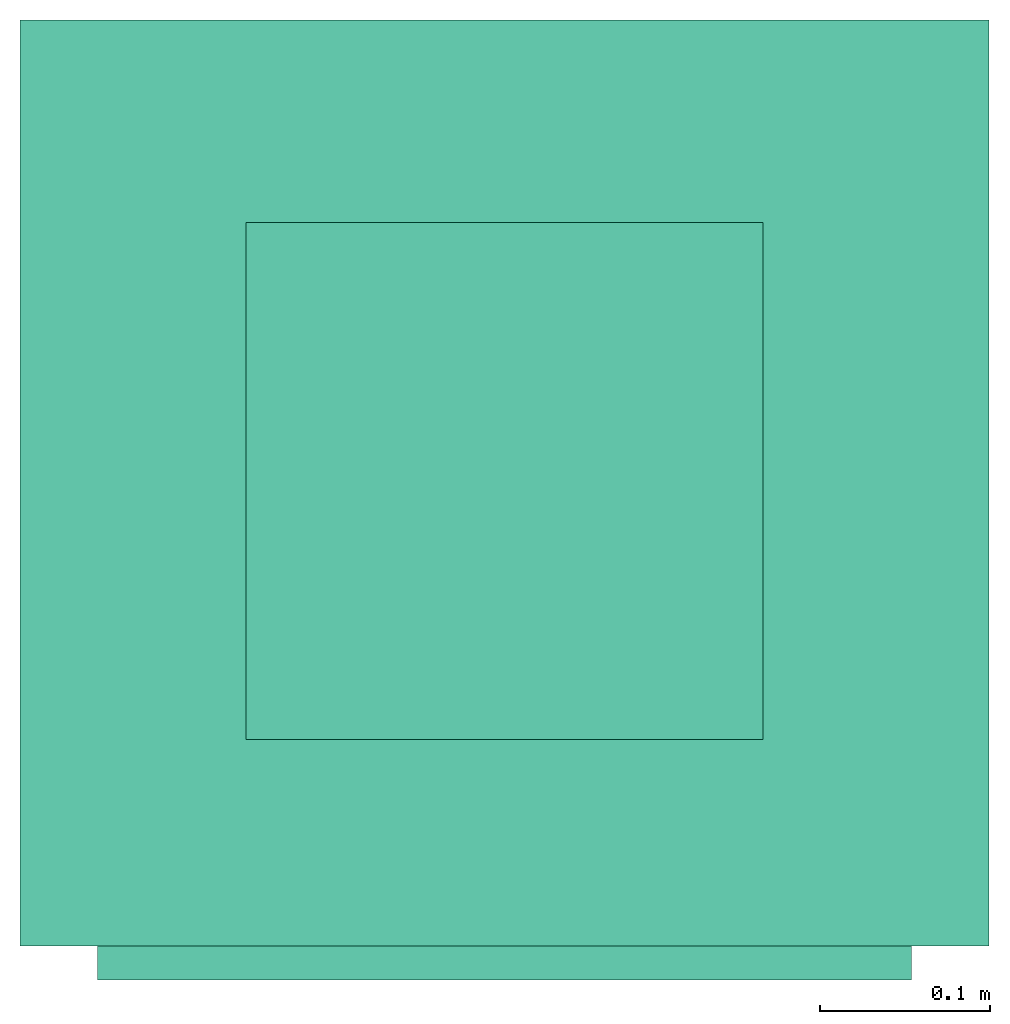
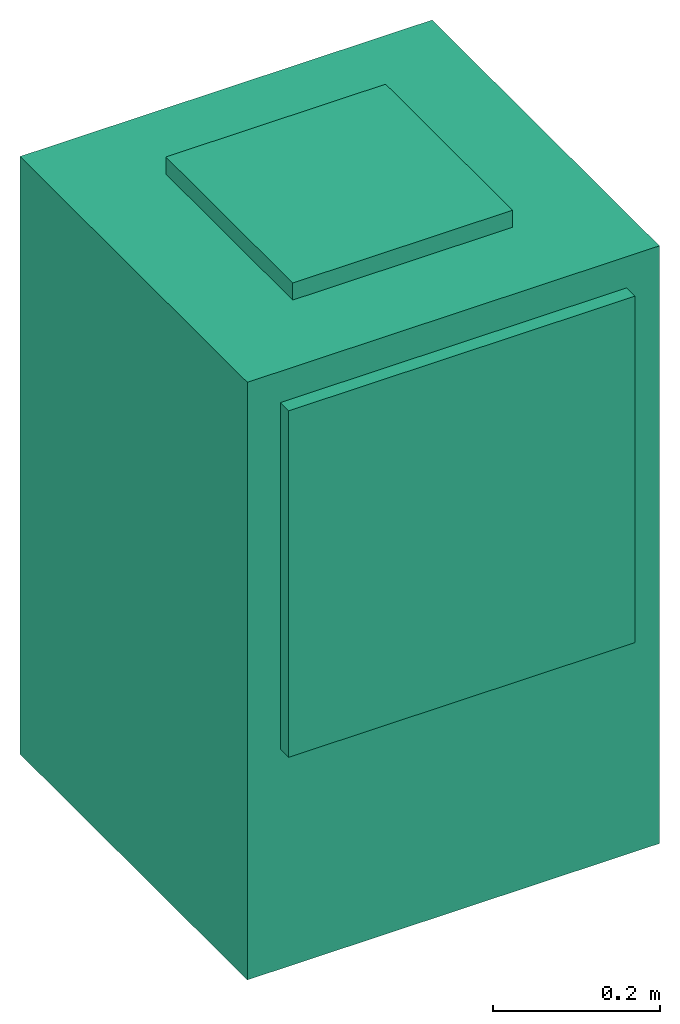
# One storey: 1 energy conversion device.
"""IFC2X3 building model written with IfcOpenShell, lengths in metres."""

from ifc_helpers import new_model, entity, si_unit, converted_unit, origin, origin_with_axes, place, context, subcontext, project, spatial, faceted_brep, type_object, element, save


model = new_model("IFC2X3")

# Units and contexts
model_context = context("Model", 3, precision=1e-05, world=origin())
body_context = subcontext(model_context, "Body", "Model", "MODEL_VIEW")
ifc_project = project(units=[si_unit("LENGTHUNIT", "METRE"), si_unit("AREAUNIT", "SQUARE_METRE"), si_unit("VOLUMEUNIT", "CUBIC_METRE"), converted_unit("PLANEANGLEUNIT", "DEGREE", entity("IfcPlaneAngleMeasure", 0.0174532925199433), si_unit("PLANEANGLEUNIT", "RADIAN"), dimensions=[0, 0, 0, 0, 0, 0, 0]), si_unit("SOLIDANGLEUNIT", "STERADIAN"), si_unit("MASSUNIT", "GRAM"), si_unit("TIMEUNIT", "SECOND"), si_unit("THERMODYNAMICTEMPERATUREUNIT", "DEGREE_CELSIUS"), si_unit("LUMINOUSINTENSITYUNIT", "LUMEN")], contexts=[model_context])

# Site, building, storey
site_placement = place(None, origin_with_axes())
site = spatial("IfcSite", under=ifc_project, at=site_placement, CompositionType="ELEMENT")
building_placement = place(site_placement, origin_with_axes())
building = spatial("IfcBuilding", under=site, at=building_placement, CompositionType="ELEMENT")
storey_placement = place(building_placement, origin_with_axes())
storey = spatial("IfcBuildingStorey", under=building, at=storey_placement, CompositionType="ELEMENT", Elevation=0.0)

# Energy conversion device
heat_exchanger_type = type_object("IfcHeatExchangerType", Name="Vertical Closet Hybrid Water-Cooled Air Conditioner", PredefinedType="NOTDEFINED")
energy_conversion_device_placement = place(storey_placement, origin_with_axes())
element("IfcEnergyConversionDevice", 1, at=energy_conversion_device_placement, inside=storey, type_object=heat_exchanger_type, Name="Vertical Closet Hybrid Water-Cooled Air Conditioner", context=body_context, shape_type="Brep", body=[
    faceted_brep([(0.240030213165283, -0.262888919639588, 0.830580019378663), (0.240030213165283, -0.282888910102844, 0.830580019378663), (0.240030213165283, -0.282888910102844, 0.322579995155334), (0.240030213165283, -0.262888919639588, 0.322579995155334), (-0.240029777145386, -0.262888919639588, 0.830580019378663), (-0.240029777145386, -0.282888910102844, 0.830580019378663), (-0.240029777145386, -0.262888919639588, 0.322579995155334), (-0.240029777145386, -0.282888910102844, 0.322579995155334), (-0.227329777145386, -0.282888910102844, 0.335279995155334), (-0.227329777145386, -0.282888910102844, 0.817880019378663), (0.227330213165283, -0.282888910102844, 0.335279995155334), (0.227330213165283, -0.282888910102844, 0.817880019378663), (0.227330213165283, -0.262888919639588, 0.335279995155334), (0.227330213165283, -0.262888919639588, 0.817880019378663), (-0.227329777145386, -0.262888919639588, 0.817880019378663), (-0.227329777145386, -0.262888919639588, 0.335279995155334)], [[[0, 1, 2]], [[2, 3, 0]], [[4, 5, 1]], [[1, 0, 4]], [[6, 7, 5]], [[5, 4, 6]], [[3, 2, 7]], [[7, 6, 3]], [[5, 7, 8]], [[8, 9, 5]], [[10, 8, 7]], [[1, 5, 9]], [[11, 10, 2]], [[2, 1, 11]], [[7, 2, 10]], [[9, 11, 1]], [[12, 13, 0]], [[0, 3, 12]], [[6, 12, 3]], [[14, 0, 13]], [[6, 4, 14]], [[14, 15, 6]], [[12, 6, 15]], [[0, 14, 4]], [[15, 14, 9]], [[9, 8, 15]], [[14, 13, 11]], [[11, 9, 14]], [[13, 12, 10]], [[10, 11, 13]], [[12, 15, 8]], [[8, 10, 12]]]),
    faceted_brep([(0.285750218009947, -0.262888919639588, 0.8763), (-0.285749781990052, -0.262888919639588, 0.8763), (-0.285749781990052, -0.262888919639588, -1.80477854883065e-16), (0.285750218009947, -0.262888919639588, -1.80477854883065e-16), (0.285750218009947, 0.283211080360412, 0.8763), (-0.285749781990052, 0.283211080360412, 0.8763), (0.285750218009947, 0.283211080360412, -1.80477854883065e-16), (-0.285749781990052, 0.283211080360412, -1.80477854883065e-16)], [[[0, 1, 2]], [[2, 3, 0]], [[1, 0, 4]], [[4, 5, 1]], [[5, 4, 6]], [[6, 7, 5]], [[1, 5, 7]], [[7, 2, 1]], [[4, 0, 3]], [[3, 6, 4]], [[2, 7, 6]], [[6, 3, 2]]]),
    faceted_brep([(-0.152399794101715, -0.140968902683258, 0.901300024414062), (-0.152399794101715, -0.140968902683258, 0.8763), (0.152400205898285, -0.140968902683258, 0.8763), (0.152400205898285, -0.140968902683258, 0.901300024414062), (-0.152399794101715, 0.163831097316742, 0.901300024414062), (-0.152399794101715, 0.163831097316742, 0.8763), (0.152400205898285, 0.163831097316742, 0.901300024414062), (0.152400205898285, 0.163831097316742, 0.8763)], [[[0, 1, 2]], [[2, 3, 0]], [[4, 5, 1]], [[1, 0, 4]], [[6, 7, 5]], [[5, 4, 6]], [[3, 2, 7]], [[7, 6, 3]], [[3, 6, 4]], [[4, 0, 3]], [[1, 5, 7]], [[7, 2, 1]]]),
    faceted_brep([(-0.227329777145386, -0.282888910102844, 0.335279995155334), (-0.227329777145386, -0.282888910102844, 0.817880019378663), (-0.227329777145386, -0.262888919639588, 0.817880019378663), (-0.227329777145386, -0.262888919639588, 0.335279995155334), (0.227330213165283, -0.282888910102844, 0.817880019378663), (0.227330213165283, -0.262888919639588, 0.817880019378663), (0.227330213165283, -0.282888910102844, 0.335279995155334), (0.227330213165283, -0.262888919639588, 0.335279995155334)], [[[0, 1, 2]], [[2, 3, 0]], [[1, 4, 5]], [[5, 2, 1]], [[4, 6, 7]], [[7, 5, 4]], [[6, 0, 3]], [[3, 7, 6]], [[1, 0, 6]], [[6, 4, 1]], [[2, 7, 3]], [[7, 2, 5]]]),
])

save(model, "model.ifc")
